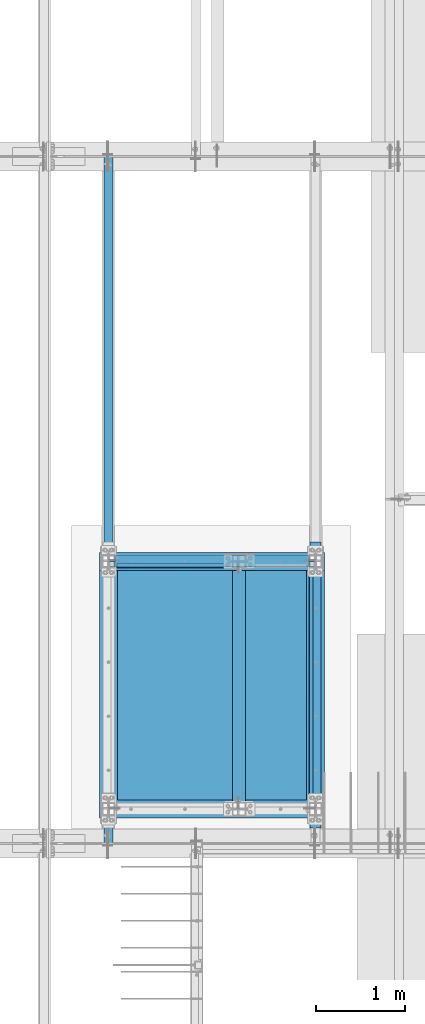
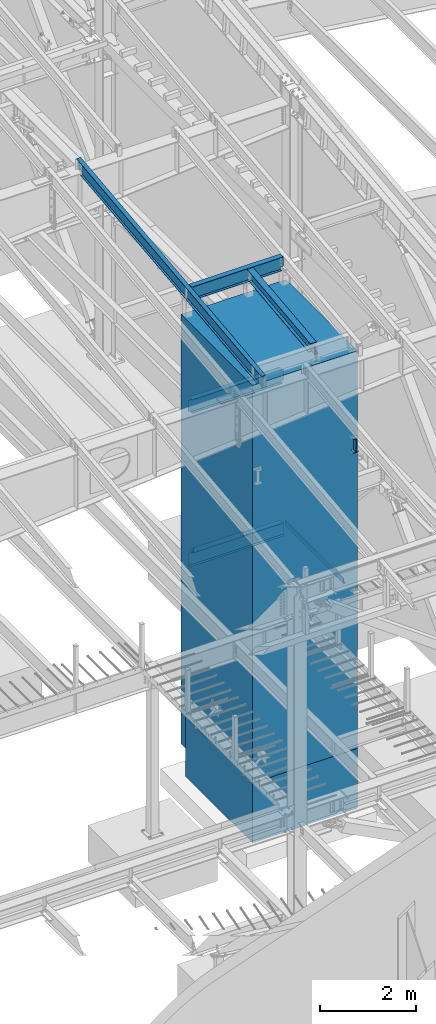
# One storey, part 722 of 1179: 11 beams, 10 elements without a shape of their own.
"""IFC2X3 building model written with IfcOpenShell, lengths in millimetres."""

import ifcopenshell
import ifcopenshell.guid

model = None  # the IFC model being written
_history = None  # IfcOwnerHistory: only IFC2X3 demands one
_inside = {}  # id of a spatial element -> (the spatial element, [elements in it])
_under = {}  # id of a project, library or spatial element -> (it, [spatial elements below it])
_declared = {}  # id of a project -> (the project, [libraries it declares])
_typed = {}  # id of a type object -> (the type object, [elements of that type])
_made_of = {}  # id of a material, layer set ... -> (it, [elements and type objects made of it])


def new_model(schema):
    """Start an empty IFC model of exactly this schema.

    Asked for "IFC4X3", IfcOpenShell would pick the latest addendum, in which some entities
    have other attributes; the version numbers below select the first issue.
    IFC2X3 requires an IfcOwnerHistory on every rooted entity: one is made here for all.
    """
    global model, _history
    if schema == "IFC4X3":
        model = ifcopenshell.file(schema_version=(4, 3, 0, 0))
    else:
        model = ifcopenshell.file(schema=schema)
    _inside.clear()
    _under.clear()
    _declared.clear()
    _typed.clear()
    _made_of.clear()
    _history = None
    if model.schema == "IFC2X3":
        org = make("IfcOrganization", Name="unknown")
        user = make(
            "IfcPersonAndOrganization",
            ThePerson=make("IfcPerson", FamilyName="unknown"),
            TheOrganization=org,
        )
        app = make(
            "IfcApplication",
            ApplicationDeveloper=org,
            Version="unknown",
            ApplicationFullName="unknown",
            ApplicationIdentifier="unknown",
        )
        _history = make(
            "IfcOwnerHistory",
            OwningUser=user,
            OwningApplication=app,
            ChangeAction="ADDED",
            CreationDate=0,
        )
    return model


def make(cls, **values):
    """One entity of the class cls with the attributes given. An attribute that is None is left unset."""
    return model.create_entity(
        cls, **{name: value for name, value in values.items() if value is not None}
    )


def rooted(cls, **values):
    """An entity with a GlobalId (a new one), such as an element, a storey or a relation."""
    return make(cls, GlobalId=ifcopenshell.guid.new(), OwnerHistory=_history, **values)


def si_unit(unit_type, name, prefix=None):
    """IfcSIUnit, for example si_unit("LENGTHUNIT", "METRE", prefix="MILLI")."""
    return make("IfcSIUnit", UnitType=unit_type, Prefix=prefix, Name=name)


def assignment(units):
    """IfcUnitAssignment: the units of a project."""
    return None if units is None else make("IfcUnitAssignment", Units=units)


def point(xyz):
    """IfcCartesianPoint."""
    return None if xyz is None else make("IfcCartesianPoint", Coordinates=xyz)


def direction(xyz):
    """IfcDirection."""
    return None if xyz is None else make("IfcDirection", DirectionRatios=xyz)


def frame(location, z_axis=None, x_axis=None):
    """IfcAxis2Placement3D, a coordinate frame: its origin and axes. An axis left out is left unset."""
    return make(
        "IfcAxis2Placement3D",
        Location=point(location),
        Axis=direction(z_axis),
        RefDirection=direction(x_axis),
    )


def origin_with_axes():
    """The frame at (0, 0, 0) with the z axis (0, 0, 1) and the x axis (1, 0, 0) written out."""
    return frame((0.0, 0.0, 0.0), z_axis=(0.0, 0.0, 1.0), x_axis=(1.0, 0.0, 0.0))


def place(relative_to, where):
    """IfcLocalPlacement: puts the frame where relative to a parent placement (None: the world)."""
    return make(
        "IfcLocalPlacement", PlacementRelTo=relative_to, RelativePlacement=where
    )


def context(
    kind, dimensions, precision=None, world=None, true_north=None, identifier=None
):
    """IfcGeometricRepresentationContext, for example the 3D "Model" context."""
    return make(
        "IfcGeometricRepresentationContext",
        ContextIdentifier=identifier,
        ContextType=kind,
        CoordinateSpaceDimension=dimensions,
        Precision=precision,
        WorldCoordinateSystem=world,
        TrueNorth=true_north,
    )


def subcontext(parent, identifier, kind, view, scale=None):
    """IfcGeometricRepresentationSubContext, for example "Body" below "Model"."""
    return make(
        "IfcGeometricRepresentationSubContext",
        ContextIdentifier=identifier,
        ContextType=kind,
        ParentContext=parent,
        TargetScale=scale,
        TargetView=view,
    )


def project(units=None, contexts=None):
    """IfcProject with its units and contexts."""
    return rooted(
        "IfcProject",
        Name="project",
        RepresentationContexts=contexts,
        UnitsInContext=assignment(units),
    )


def spatial(cls, under=None, at=None, **own):
    """A site, building, storey or space (cls), placed at a placement, below another one or the project."""
    s = rooted(cls, ObjectPlacement=at, **own)
    if under is not None:
        _under.setdefault(under.id(), (under, []))[1].append(s)
    return s


def faces_of(points, faces, orient=None, outer=None):
    """IfcFace entities. A face is a list of loops; a loop is a list of indices into points, from 0.

    orient and outer hold one flag for each loop. By default every Orientation is true, the
    first loop of a face is its IfcFaceOuterBound and the others are IfcFaceBound.
    """
    made = []
    for i, loops in enumerate(faces):
        bounds = []
        for j, loop in enumerate(loops):
            is_outer = j == 0 if outer is None else outer[i][j]
            bounds.append(
                make(
                    "IfcFaceOuterBound" if is_outer else "IfcFaceBound",
                    Bound=make("IfcPolyLoop", Polygon=[points[k] for k in loop]),
                    Orientation=True if orient is None else orient[i][j],
                )
            )
        made.append(make("IfcFace", Bounds=bounds))
    return made


def faceted_brep(points, faces, orient=None, outer=None, voids=None):
    """IfcFacetedBrep: a solid bounded by flat faces; with voids (closed shells), ...WithVoids."""
    shared = [point(p) for p in points]
    hull = make("IfcClosedShell", CfsFaces=faces_of(shared, faces, orient, outer))
    if voids is None:
        return make("IfcFacetedBrep", Outer=hull)
    return make(
        "IfcFacetedBrepWithVoids",
        Outer=hull,
        Voids=[
            make(cls, CfsFaces=faces_of(shared, fs, o, b)) for cls, fs, o, b in voids
        ],
    )


def shape(context_of_items, identifier, shape_type, items):
    """IfcShapeRepresentation: the items that make up one representation, for example the "Body"."""
    return make(
        "IfcShapeRepresentation",
        ContextOfItems=context_of_items,
        RepresentationIdentifier=identifier,
        RepresentationType=shape_type,
        Items=items,
    )


def material(Name=None, Category=None):
    """IfcMaterial."""
    return make("IfcMaterial", Name=Name, Category=Category)


def made_of(thing, what):
    """Note that an element or type object is made of a material, layer set ...; save() writes the relation."""
    if what is not None:
        _made_of.setdefault(what.id(), (what, []))[1].append(thing)
    return thing


def type_object(cls, material=None, **own):
    """A type object (cls), such as IfcWallType, which elements share."""
    return made_of(rooted(cls, **own), material)


def element(
    cls,
    number,
    at=None,
    inside=None,
    cuts=None,
    type_object=None,
    material=None,
    context=None,
    identifier="Body",
    shape_type=None,
    held_by="IfcProductDefinitionShape",
    body=None,
    shapes=None,
    **own,
):
    """One element of the class cls, such as IfcWall. Its Tag is "e" and its number.

    at: its placement. inside: the storey or other place that contains it. cuts: it is an
    opening in that element (IfcRelVoidsElement). A single representation is given by context,
    identifier, shape_type and body (its items); several are given by shapes. held_by: the class
    of the entity that holds the representations. save() writes the other relations.
    """
    e = rooted(cls, Tag="e%d" % number, ObjectPlacement=at, **own)
    if body is not None:
        shapes = [shape(context, identifier, shape_type, body)]
    if shapes is not None:
        e.Representation = make(held_by, Representations=shapes)
    if inside is not None:
        _inside.setdefault(inside.id(), (inside, []))[1].append(e)
    if cuts is not None:
        rooted(
            "IfcRelVoidsElement", RelatingBuildingElement=cuts, RelatedOpeningElement=e
        )
    if type_object is not None:
        _typed.setdefault(type_object.id(), (type_object, []))[1].append(e)
    return made_of(e, material)


def aggregate(whole, parts):
    """IfcRelAggregates: a whole, such as a stair, and the parts it consists of."""
    return rooted("IfcRelAggregates", RelatingObject=whole, RelatedObjects=parts)


def save(model, path):
    """Write the relations noted so far, then the file.

    IfcRelAggregates (storeys below a building ...), IfcRelContainedInSpatialStructure (elements
    in a storey), IfcRelDefinesByType, IfcRelAssociatesMaterial and IfcRelDeclares: one each for
    every whole, place, type object, material and project.
    """
    for whole, parts in _under.values():
        aggregate(whole, parts)
    for where, things in _inside.values():
        rooted(
            "IfcRelContainedInSpatialStructure",
            RelatedElements=things,
            RelatingStructure=where,
        )
    for kind, things in _typed.values():
        rooted("IfcRelDefinesByType", RelatedObjects=things, RelatingType=kind)
    for what, things in _made_of.values():
        rooted("IfcRelAssociatesMaterial", RelatedObjects=things, RelatingMaterial=what)
    for by, libraries in _declared.values():
        rooted("IfcRelDeclares", RelatingContext=by, RelatedDefinitions=libraries)
    model.write(path)


model = new_model("IFC2X3")

# Units and contexts
model_context = context("Model", 3, precision=1e-05, world=origin_with_axes())
body_context = subcontext(model_context, "Body", "Model", "MODEL_VIEW")
ifc_project = project(units=[si_unit("LENGTHUNIT", "METRE", prefix="MILLI"), si_unit("AREAUNIT", "SQUARE_METRE"), si_unit("VOLUMEUNIT", "CUBIC_METRE"), si_unit("MASSUNIT", "GRAM", prefix="KILO"), si_unit("TIMEUNIT", "SECOND"), si_unit("PLANEANGLEUNIT", "RADIAN"), si_unit("SOLIDANGLEUNIT", "STERADIAN"), si_unit("THERMODYNAMICTEMPERATUREUNIT", "DEGREE_CELSIUS"), si_unit("LUMINOUSINTENSITYUNIT", "LUMEN")], contexts=[model_context])

# Site, building, storey
site_placement = place(None, origin_with_axes())
site = spatial("IfcSite", under=ifc_project, at=site_placement, CompositionType="ELEMENT")
building_placement = place(site_placement, origin_with_axes())
building = spatial("IfcBuilding", under=site, at=building_placement, Name="Undefined", CompositionType="ELEMENT")
storey_placement = place(building_placement, origin_with_axes())
storey = spatial("IfcBuildingStorey", under=building, at=storey_placement, Name="Undefined", CompositionType="ELEMENT", Elevation=0.0)

# Assembly, beam
assembly_1_placement = place(storey_placement, origin_with_axes())
assembly_1 = element("IfcElementAssembly", 1, at=assembly_1_placement, inside=storey, Name="BEAM", AssemblyPlace="NOTDEFINED", PredefinedType="RIGID_FRAME")
ifc_material_1 = material(Name="STEEL/A992")
beam_type_1 = type_object("IfcBeamType", Name="W10X22", PredefinedType="NOTDEFINED")
beam_1_placement = place(assembly_1_placement, frame((20612.1000000001, 11882.5883300328, 10453.0155913628), z_axis=(0.0, -0.112284087038017, 0.993676146336441), x_axis=(0.0, 0.993676146336441, 0.112284087038017)))
beam_1 = element("IfcBeam", 2, at=beam_1_placement, type_object=beam_type_1, material=ifc_material_1, Name="BEAM", ObjectType="W10X22", context=body_context, shape_type="Brep", body=[
    faceted_brep([(114.643012563729, 3.37393741607593, -119.062499999978), (114.643012563725, 3.37393741607593, -128.587499999972), (-13.0844039856984, 3.37393741607593, -128.587499999921), (-12.0080916147308, 3.17499999999927, -119.062499999927), (114.643012563729, 73.0250000000015, -119.062499999978), (114.643012563725, 73.0250000000015, -128.587499999972), (75.608631949508, 3.17499999999927, 119.062499999904), (75.608631949508, 73.0250000000015, 119.062499999904), (2734.02003668513, 73.0250000000015, 119.062499998825), (2734.02003668513, 3.17499999999927, 119.062499998825), (76.6849443204737, -73.0250000000015, 128.587499999898), (76.6849443204737, 73.0250000000015, 128.587499999898), (74.2065444502277, 3.17499999999927, 106.654500435005), (74.2065444502277, -3.17499999999927, 106.654500435005), (75.608631949508, -3.17499999999927, 119.062499999904), (75.608631949508, -73.0250000000015, 119.062499999904), (72.700218394586, 3.17499999999927, 101.9337037354), (72.700218394586, -3.17499999999927, 101.9337037354), (69.5019838979915, 3.17499999999927, 98.1487023127211), (69.5019838979915, -3.17499999999927, 98.1487023127211), (65.0987431704762, 3.17499999999927, 95.8757283224459), (65.0987431704762, -3.17499999999927, 95.8757283224459), (60.1608496973295, 3.17499999999927, 95.4608214500367), (60.1608496973295, -3.17499999999927, 95.4608214500367), (12.8370230384862, 3.17499999999927, 100.808351116644), (12.8370230384862, -3.17499999999927, 100.808351116644), (-12.0080916147308, -3.17499999999927, -119.062499999927), (-12.0080916147308, -73.0250000000015, -119.062499999927), (2767.82114171815, -73.0250000000015, -119.062500001055), (2767.82114171815, -3.17499999999927, -119.062500001055), (-13.0844039856984, -73.0250000000015, -128.587499999921), (2766.74482934718, -73.0250000000015, -128.587500001049), (2639.01741279884, 3.17499999999927, -119.062500001002), (2639.01741279883, 3.37393741607593, -128.587500000996), (2639.01741279883, 73.0250000000015, -128.587500000996), (2639.01741279884, 73.0250000000015, -119.062500001002), (2767.82114171815, 3.17499999999927, -119.062500001055), (2766.74482934718, 3.37393741607593, -128.587500001049), (2773.92024515364, 3.17499999999927, -65.0875000010201), (2791.45772885094, 3.17499999999927, 90.1132918162257), (2791.45772885094, -3.17499999999927, 90.1132918162257), (2739.41310547559, -3.17499999999927, 96.9671475403811), (2735.62810405291, -3.17499999999927, 100.165382036977), (2733.35513006264, -3.17499999999927, 104.568622764493), (2732.94022319023, -3.17499999999927, 109.506516237638), (2734.02003668513, -3.17499999999927, 119.062499998825), (2744.13390217519, -3.17499999999927, 95.4608214847431), (2734.02003668513, -73.0250000000015, 119.062499998825), (2735.0963490561, -73.0250000000015, 128.587499998819), (2735.0963490561, 73.0250000000015, 128.587499998819), (2732.94022319023, 3.17499999999927, 109.506516237638), (2733.35513006264, 3.17499999999927, 104.568622764493), (2735.62810405291, 3.17499999999927, 100.165382036977), (2739.41310547559, 3.17499999999927, 96.9671475403811), (2744.13390217519, 3.17499999999927, 95.4608214847431), (-5.90898817924426, 3.17499999999927, -65.0874999998869)], [[[0, 1, 2, 3]], [[4, 5, 1, 0]], [[6, 7, 8, 9]], [[10, 11, 7, 6, 12, 13, 14, 15]], [[13, 12, 16, 17]], [[17, 16, 18, 19]], [[19, 18, 20, 21]], [[21, 20, 22, 23]], [[23, 22, 24, 25]], [[26, 27, 28, 29]], [[27, 30, 31, 28]], [[32, 33, 34, 35]], [[36, 37, 33, 32]], [[38, 39, 40, 29, 28, 31, 37, 36]], [[41, 42, 43, 44, 45, 14, 13, 17, 19, 21, 23, 25, 26, 29, 40, 46]], [[15, 14, 45, 47]], [[10, 15, 47, 48]], [[11, 10, 48, 49]], [[7, 11, 49, 8]], [[48, 47, 45, 44, 50, 9, 8, 49]], [[43, 51, 50, 44]], [[42, 52, 51, 43]], [[41, 53, 52, 42]], [[46, 54, 53, 41]], [[40, 39, 54, 46]], [[38, 36, 32, 0, 3, 55, 24, 22, 20, 18, 16, 12, 6, 9, 50, 51, 52, 53, 54, 39]], [[30, 27, 26, 25, 24, 55, 3, 2]], [[34, 33, 37, 31, 30, 2, 1, 5]], [[35, 34, 5, 4]], [[32, 35, 4, 0]]]),
])
aggregate(assembly_1, [beam_1])

assembly_2_placement = place(storey_placement, origin_with_axes())
assembly_2 = element("IfcElementAssembly", 3, at=assembly_2_placement, inside=storey, Name="BEAM", AssemblyPlace="NOTDEFINED", PredefinedType="RIGID_FRAME")
ifc_material_2 = material(Name="STEEL/A36")
beam_type_2 = type_object("IfcBeamType", PredefinedType="NOTDEFINED")
beam_2_placement = place(assembly_2_placement, frame((19837.4000030518, 14589.125, 4235.45000610352), z_axis=(1.0, 0.0, 0.0), x_axis=(0.0, 0.0, -1.0)))
beam_2 = element("IfcBeam", 4, at=beam_2_placement, type_object=beam_type_2, material=ifc_material_2, Name="BENT_PLATE", context=body_context, shape_type="Brep", body=[
    faceted_brep([(0.0, -3.17499999999927, -603.25), (0.0, -3.17499999999927, 603.25), (0.0, 3.17499999999927, 603.25), (0.0, 3.17499999999927, -603.25), (127.000006103516, 3.17499999999927, 603.25), (127.000006103516, 3.17499999999927, -603.25), (133.350006103517, -3.17499999999927, -603.25), (133.350006103517, -3.17499999999927, 603.25), (127.000006103516, 47.6250000000018, 603.25), (127.000006103516, 47.6250000000018, -603.25), (133.350006103517, 47.6250000000018, 603.25), (133.350006103517, 47.6250000000018, -603.25)], [[[0, 1, 2, 3]], [[3, 2, 4, 5]], [[1, 0, 6, 7]], [[5, 4, 8, 9]], [[4, 2, 1, 7, 10, 8]], [[7, 6, 11, 10]], [[6, 0, 3, 5, 9, 11]], [[10, 11, 9, 8]]]),
])

assembly_3_placement = place(storey_placement, origin_with_axes())
assembly_3 = element("IfcElementAssembly", 5, at=assembly_3_placement, inside=storey, Name="BEAM", AssemblyPlace="NOTDEFINED", PredefinedType="RIGID_FRAME")
beam_type_3 = type_object("IfcBeamType", Name="W14X22", PredefinedType="NOTDEFINED")
beam_3_placement = place(assembly_3_placement, frame((19138.9, 14662.15, 10721.8832183146), z_axis=(0.0, 0.0, 1.0), x_axis=(1.0, 0.0, 0.0)))
beam_3 = element("IfcBeam", 6, at=beam_3_placement, type_object=beam_type_3, material=ifc_material_1, Name="BEAM", ObjectType="W14X22", context=body_context, shape_type="Brep", body=[
    faceted_brep([(2244.725, -3.17499999999927, -166.6875), (2244.725, -63.5, -166.6875), (2244.725, -63.5, -174.625), (2244.725, 63.5, -174.625), (2244.725, 63.5, -166.6875), (2244.725, 3.17499999999927, -166.6875), (2244.725, 3.17499999999927, -123.824999806495), (2244.725, -3.17499999999927, -123.824999806495), (2245.69172992259, 3.17499999999927, -118.964920288448), (2245.69172992259, -3.17499999999927, -118.964920288448), (2248.44474382306, 3.17499999999927, -114.844743820295), (2248.44474382306, -3.17499999999927, -114.844743820295), (2252.56492029122, 3.17499999999927, -112.091729919817), (2252.56492029122, -3.17499999999927, -112.091729919817), (2257.42499980926, 3.17499999999927, -111.12499999723), (2257.42499980926, -3.17499999999927, -111.12499999723), (2320.925, -3.17499999999927, -111.12499999723), (2320.925, 3.17499999999927, -111.12499999723), (66.6749999999993, 3.17499999999927, 166.6875), (66.6749999999993, 63.5, 166.6875), (2270.125, 63.5, 166.6875), (2270.125, 3.17499999999927, 166.6875), (92.0750000000007, -3.17499999999927, -123.824999806491), (92.0750000000007, 3.17499999999927, -123.824999806491), (92.0750000000007, 3.17499999999927, -166.6875), (92.0750000000007, 63.5, -166.6875), (92.0750000000007, 63.5, -174.625), (92.0750000000007, -63.5, -174.625), (92.0750000000007, -63.5, -166.6875), (92.0750000000007, -3.17499999999927, -166.6875), (91.1082700774132, -3.17499999999927, -118.964920288445), (91.1082700774132, 3.17499999999927, -118.964920288445), (88.3552561769357, -3.17499999999927, -114.844743820291), (88.3552561769357, 3.17499999999927, -114.844743820291), (84.235079708782, -3.17499999999927, -112.091729919814), (84.235079708782, 3.17499999999927, -112.091729919814), (79.3750001907356, -3.17499999999927, -111.124999997226), (79.3750001907356, 3.17499999999927, -111.124999997226), (15.875, -3.17499999999927, -111.124999997226), (15.875, 3.17499999999927, -111.124999997226), (15.875, -3.17499999999927, 149.225000002774), (15.875, 3.17499999999927, 149.225000002774), (53.9750001907341, -3.17499999999927, 149.225000002774), (53.9750001907341, 3.17499999999927, 149.225000002774), (58.8350797087805, -3.17499999999927, 150.191729925362), (58.8350797087805, 3.17499999999927, 150.191729925362), (62.9552561769342, -3.17499999999927, 152.944743825839), (62.9552561769342, 3.17499999999927, 152.944743825839), (65.7082700774117, -3.17499999999927, 157.064920293993), (65.7082700774117, 3.17499999999927, 157.064920293993), (66.6749999999993, -3.17499999999927, 161.924999812039), (66.6749999999993, 3.17499999999927, 161.924999812039), (66.6749999999993, -63.5, 174.625), (66.6749999999993, 63.5, 174.625), (66.6749999999993, -3.17499999999927, 166.6875), (66.6749999999993, -63.5, 166.6875), (2270.125, -3.17499999999927, 166.6875), (2270.125, -63.5, 166.6875), (2270.125, -63.5, 174.625), (2270.125, 63.5, 174.625), (2270.125, -3.17499999999927, 161.924999812036), (2270.125, 3.17499999999927, 161.924999812036), (2271.09172992259, -3.17499999999927, 157.064920293989), (2271.09172992259, 3.17499999999927, 157.064920293989), (2273.84474382307, -3.17499999999927, 152.944743825836), (2273.84474382307, 3.17499999999927, 152.944743825836), (2277.96492029122, -3.17499999999927, 150.191729925358), (2277.96492029122, 3.17499999999927, 150.191729925358), (2282.82499980927, -3.17499999999927, 149.225000002771), (2282.82499980927, 3.17499999999927, 149.225000002771), (2320.925, -3.17499999999927, 149.225000002771), (2320.925, 3.17499999999927, 149.225000002771)], [[[0, 1, 2, 3, 4, 5, 6, 7]], [[7, 6, 8, 9]], [[9, 8, 10, 11]], [[11, 10, 12, 13]], [[13, 12, 14, 15]], [[16, 15, 14, 17]], [[18, 19, 20, 21]], [[22, 23, 24, 25, 26, 27, 28, 29]], [[30, 31, 23, 22]], [[32, 33, 31, 30]], [[34, 35, 33, 32]], [[36, 37, 35, 34]], [[38, 39, 37, 36]], [[40, 41, 39, 38]], [[42, 43, 41, 40]], [[44, 45, 43, 42]], [[46, 47, 45, 44]], [[48, 49, 47, 46]], [[50, 51, 49, 48]], [[52, 53, 19, 18, 51, 50, 54, 55]], [[55, 54, 56, 57]], [[52, 55, 57, 58]], [[53, 52, 58, 59]], [[19, 53, 59, 20]], [[58, 57, 56, 60, 61, 21, 20, 59]], [[62, 63, 61, 60]], [[64, 65, 63, 62]], [[66, 67, 65, 64]], [[68, 69, 67, 66]], [[70, 71, 69, 68]], [[71, 70, 16, 17]], [[12, 10, 8, 6, 5, 24, 23, 31, 33, 35, 37, 39, 41, 43, 45, 47, 49, 51, 18, 21, 61, 63, 65, 67, 69, 71, 17, 14]], [[25, 24, 5, 4]], [[26, 25, 4, 3]], [[27, 26, 3, 2]], [[28, 27, 2, 1]], [[29, 28, 1, 0]], [[70, 68, 66, 64, 62, 60, 56, 54, 50, 48, 46, 44, 42, 40, 38, 36, 34, 32, 30, 22, 29, 0, 7, 9, 11, 13, 15, 16]]]),
])
aggregate(assembly_3, [beam_3])

assembly_4_placement = place(storey_placement, origin_with_axes())
assembly_4 = element("IfcElementAssembly", 7, at=assembly_4_placement, inside=storey, Name="BEAM", AssemblyPlace="NOTDEFINED", PredefinedType="RIGID_FRAME")
beam_4_placement = place(assembly_4_placement, frame((21475.7, 11652.2500015259, 7839.075), z_axis=(0.0, 0.0, 1.0), x_axis=(0.0, 1.0, 0.0)))
beam_4 = element("IfcBeam", 8, at=beam_4_placement, type_object=beam_type_3, material=ifc_material_1, Name="BEAM", ObjectType="W14X22", context=body_context, shape_type="Brep", body=[
    faceted_brep([(0.0, 63.5, -174.625), (0.0, 63.5, -166.6875), (3225.79999694824, 63.5, -166.6875), (3225.79999694824, 63.5, -174.625), (-1.21872290037572e-10, 3.17500000000018, -166.687500000036), (3225.79999694824, 3.17499999999927, -166.6875), (1.20053300634027e-10, 3.17500000000018, 166.687500000036), (3225.79999694824, 3.17499999999927, 166.6875), (0.0, 63.5, 166.6875), (3225.79999694824, 63.5, 166.6875), (0.0, 63.5, 174.625), (3225.79999694824, 63.5, 174.625), (0.0, -63.5, 174.625), (3225.79999694824, -63.5, 174.625), (0.0, -63.5, 166.6875), (3225.79999694824, -63.5, 166.6875), (1.20053300634027e-10, -3.17500000000018, 166.687500000036), (3225.79999694824, -3.17499999999927, 166.6875), (-1.21872290037572e-10, -3.17500000000018, -166.687500000036), (3225.79999694824, -3.17499999999927, -166.6875), (0.0, -63.5, -166.6875), (3225.79999694824, -63.5, -166.6875), (0.0, -63.5, -174.625), (3225.79999694824, -63.5, -174.625)], [[[0, 1, 2, 3]], [[1, 4, 5, 2]], [[4, 6, 7, 5]], [[6, 8, 9, 7]], [[8, 10, 11, 9]], [[10, 12, 13, 11]], [[12, 14, 15, 13]], [[14, 16, 17, 15]], [[16, 18, 19, 17]], [[18, 20, 21, 19]], [[20, 22, 23, 21]], [[22, 0, 3, 23]], [[5, 7, 9, 11, 13, 15, 17, 19, 21, 23, 3, 2]], [[22, 20, 18, 16, 14, 12, 10, 8, 6, 4, 1, 0]]]),
])
aggregate(assembly_4, [beam_4])

assembly_5_placement = place(storey_placement, origin_with_axes())
assembly_5 = element("IfcElementAssembly", 9, at=assembly_5_placement, inside=storey, Name="BEAM", AssemblyPlace="NOTDEFINED", PredefinedType="RIGID_FRAME")
beam_5_placement = place(assembly_5_placement, frame((19138.9, 14662.15, 7839.075), z_axis=(0.0, 0.0, 1.0), x_axis=(1.0, 0.0, 0.0)))
beam_5 = element("IfcBeam", 10, at=beam_5_placement, type_object=beam_type_3, material=ifc_material_1, Name="BEAM", ObjectType="W14X22", context=body_context, shape_type="Brep", body=[
    faceted_brep([(15.8749999999964, -3.17499999999927, -142.875), (15.8749999999964, 3.17499999999927, -142.875), (66.6750001907349, 3.17499999999927, -142.875), (66.6750001907349, -3.17499999999927, -142.875), (71.5350797087813, 3.17499999999927, -143.841729922588), (71.5350797087813, -3.17499999999927, -143.841729922588), (75.6552561769349, 3.17499999999927, -146.594743823066), (75.6552561769349, -3.17499999999927, -146.594743823066), (78.4082700774125, 3.17499999999927, -150.71492029122), (78.4082700774125, -3.17499999999927, -150.71492029122), (79.375, -3.17499999999927, -155.574999809265), (79.375, 3.17499999999927, -155.574999809265), (79.375, 3.17499999999927, -166.6875), (79.375, 63.5, -166.6875), (79.375, 63.5, -174.625), (79.375, -63.5, -174.625), (79.375, -63.5, -166.6875), (79.375, -3.17499999999927, -166.6875), (76.2000000000007, 3.17499999999927, 166.6875), (76.2000000000007, 63.5, 166.6875), (2260.59999999999, 63.5, 166.6875), (2260.59999999999, 3.17499999999927, 166.6875), (63.5, -3.17499999993015, 142.874999807531), (63.5, 3.1750000039101, 142.874999807529), (15.8750000000018, 3.17500000000291, 142.874999999998), (15.8750000000018, -3.17500000000291, 142.874999999998), (68.360079708782, -3.17499999999927, 143.841729922588), (68.360079708782, 3.17499999999927, 143.841729922588), (72.4802561769357, -3.17499999999927, 146.594743823066), (72.4802561769357, 3.17499999999927, 146.594743823066), (75.2332700774132, -3.17499999999927, 150.71492029122), (75.2332700774132, 3.17499999999927, 150.71492029122), (76.2000000000007, -3.17499999999927, 155.574999809265), (76.2000000000007, 3.17499999999927, 155.574999809265), (76.2000000000007, 63.5, 174.625), (76.2000000000007, -63.5, 174.625), (2260.59999999999, -63.5, 174.625), (2260.59999999999, 63.5, 174.625), (76.2000000000007, -63.5, 166.6875), (2260.59999999999, -63.5, 166.6875), (76.2000000000007, -3.17499999999927, 166.6875), (2260.59999999999, -3.17499999999927, 166.6875), (2260.59999999999, -3.17499999999927, 155.574999809265), (2260.59999999999, 3.17499999999927, 155.574999809265), (2261.56672992258, -3.17499999999927, 150.71492029122), (2261.56672992258, 3.17499999999927, 150.71492029122), (2264.31974382306, -3.17499999999927, 146.594743823066), (2264.31974382306, 3.17499999999927, 146.594743823066), (2268.43992029121, -3.17499999999927, 143.841729922588), (2268.43992029121, 3.17499999999927, 143.841729922588), (2273.29999980926, -3.17499999999927, 142.875), (2273.29999980926, 3.17499999999927, 142.875), (2320.925, -3.17499999999927, 142.875), (2320.925, 3.17499999999927, 142.875), (2320.925, -3.17499999999927, -142.875), (2320.925, 3.17499999999927, -142.875), (2270.12499980926, -3.17499999999927, -142.875), (2270.12499980926, 3.17499999999927, -142.875), (2265.26492029121, -3.17499999999927, -143.841729922588), (2265.26492029121, 3.17499999999927, -143.841729922588), (2261.14474382306, -3.17499999999927, -146.594743823066), (2261.14474382306, 3.17499999999927, -146.594743823066), (2258.39172992258, -3.17499999999927, -150.71492029122), (2258.39172992258, 3.17499999999927, -150.71492029122), (2257.42499999999, -3.17499999999927, -155.574999809265), (2257.42499999999, 3.17499999999927, -155.574999809265), (2257.42499999999, -3.17499999999927, -166.6875), (2257.42499999999, -63.5, -166.6875), (2257.42499999999, -63.5, -174.625), (2257.42499999999, 63.5, -174.625), (2257.42499999999, 63.5, -166.6875), (2257.42499999999, 3.17499999999927, -166.6875)], [[[0, 1, 2, 3]], [[3, 2, 4, 5]], [[5, 4, 6, 7]], [[7, 6, 8, 9]], [[10, 11, 12, 13, 14, 15, 16, 17]], [[9, 8, 11, 10]], [[18, 19, 20, 21]], [[22, 23, 24, 25]], [[26, 27, 23, 22]], [[28, 29, 27, 26]], [[30, 31, 29, 28]], [[32, 33, 31, 30]], [[34, 35, 36, 37]], [[35, 38, 39, 36]], [[38, 40, 41, 39]], [[35, 34, 19, 18, 33, 32, 40, 38]], [[19, 34, 37, 20]], [[36, 39, 41, 42, 43, 21, 20, 37]], [[44, 45, 43, 42]], [[46, 47, 45, 44]], [[48, 49, 47, 46]], [[50, 51, 49, 48]], [[52, 53, 51, 50]], [[53, 52, 54, 55]], [[54, 56, 57, 55]], [[58, 59, 57, 56]], [[60, 61, 59, 58]], [[62, 63, 61, 60]], [[64, 65, 63, 62]], [[66, 67, 68, 69, 70, 71, 65, 64]], [[17, 16, 67, 66]], [[16, 15, 68, 67]], [[15, 14, 69, 68]], [[14, 13, 70, 69]], [[13, 12, 71, 70]], [[59, 61, 63, 65, 71, 12, 11, 8, 6, 4, 2, 1, 24, 23, 27, 29, 31, 33, 18, 21, 43, 45, 47, 49, 51, 53, 55, 57]], [[25, 24, 1, 0]], [[52, 50, 48, 46, 44, 42, 41, 40, 32, 30, 28, 26, 22, 25, 0, 3, 5, 7, 9, 10, 17, 66, 64, 62, 60, 58, 56, 54]]]),
])
aggregate(assembly_5, [beam_5])

# Beam
beam_6_placement = place(assembly_2_placement, frame((19138.9, 14662.15, 3927.475), z_axis=(0.0, 0.0, 1.0), x_axis=(1.0, 0.0, 0.0)))
beam_6 = element("IfcBeam", 11, at=beam_6_placement, type_object=beam_type_3, material=ifc_material_1, Name="BEAM", ObjectType="W14X22", context=body_context, shape_type="Brep", body=[
    faceted_brep([(69.8500001907341, -3.17500000000291, 142.874999999998), (69.8500001907341, 3.17497569180705, 142.874999999998), (15.8750000000018, 3.17500000000291, 142.874999999998), (15.8750000000018, -3.17500000000291, 142.874999999998), (74.7100797087805, -3.17500000000291, 143.841729922586), (74.7100797087805, 3.17497496696888, 143.841729922586), (78.8302561769342, -3.17500000000291, 146.594743823063), (78.8302561769342, 3.17497290281608, 146.594743823063), (81.5832700774117, -3.17500000000291, 150.714920291217), (81.5832700774117, 3.17496981359, 150.714920291217), (82.5499999999993, -3.17500000000291, 155.574999809263), (82.5499999999993, 3.17496616959397, 155.574999809263), (82.5499999999993, -63.5, 174.625), (82.5499999999993, 63.5, 174.625), (82.5499999999993, 63.5, 166.6875), (82.5499999999993, 3.17500000000291, 166.6875), (82.5499999999993, -3.17500000000291, 166.6875), (82.5499999999993, -63.5, 166.6875), (142.875000000002, 63.5, -166.6875), (142.875000000002, 3.17549991607666, -166.6875), (2193.92499999986, 3.17502914962461, -166.6875), (2193.925, 63.5, -166.6875), (15.8750000000018, -3.17500000000291, -166.6875), (15.8750000000018, -63.5, -166.6875), (2320.925, -63.5, -166.6875), (2320.925, -3.17499999999927, -166.6875), (15.8750000000018, -63.5, -174.625), (2320.925, -63.5, -174.625), (2193.925, 63.5, -174.625), (2193.925, 3.17549991607666, -174.625), (2320.925, 3.17549991607666, -174.625), (15.8750000000018, 3.17549991607666, -174.625), (142.875000000002, 3.17549991607666, -174.625), (142.875000000002, 63.5, -174.625), (15.8750000000018, 3.17500000000291, -166.6875), (2320.925, 3.17499999999927, -166.6875), (2320.925, 3.17499999999927, 142.875), (2320.925, -3.17499999999927, 142.875), (2266.94999980927, 3.17496467120691, 142.875), (2266.94999980927, -3.17499999999927, 142.875), (2262.08992029122, 3.17496394012414, 143.841729922588), (2262.08992029122, -3.17499999999927, 143.841729922588), (2257.96974382307, 3.17496186523749, 146.594743823066), (2257.96974382307, -3.17499999999927, 146.594743823066), (2255.21672992259, 3.17495876243083, 150.71492029122), (2255.21672992259, -3.17499999999927, 150.71492029122), (2254.25, 3.17495510407934, 155.574999809265), (2254.25, -3.17499999999927, 155.574999809265), (2254.25, -63.5, 174.625), (2254.25, -63.5, 166.6875), (2254.25, -3.17499999999927, 166.6875), (2254.25, 3.17499999999927, 166.6875), (2254.25, 63.5, 166.6875), (2254.25, 63.5, 174.625)], [[[0, 1, 2, 3]], [[4, 5, 1, 0]], [[6, 7, 5, 4]], [[8, 9, 7, 6]], [[10, 11, 9, 8]], [[12, 13, 14, 15, 11, 10, 16, 17]], [[18, 19, 20, 21]], [[22, 23, 24, 25]], [[23, 26, 27, 24]], [[28, 29, 30, 27, 26, 31, 32, 33]], [[19, 32, 31, 34]], [[18, 33, 32, 19]], [[33, 18, 21, 28]], [[20, 29, 28, 21]], [[35, 30, 29, 20]], [[25, 24, 27, 30, 35, 36, 37]], [[37, 36, 38, 39]], [[39, 38, 40, 41]], [[41, 40, 42, 43]], [[43, 42, 44, 45]], [[45, 44, 46, 47]], [[48, 49, 50, 47, 46, 51, 52, 53]], [[12, 17, 49, 48]], [[17, 16, 50, 49]], [[41, 43, 45, 47, 50, 16, 10, 8, 6, 4, 0, 3, 22, 25, 37, 39]], [[34, 31, 26, 23, 22, 3, 2]], [[35, 20, 19, 34, 2, 1, 5, 7, 9, 11, 15, 51, 46, 44, 42, 40, 38, 36]], [[15, 14, 52, 51]], [[14, 13, 53, 52]], [[13, 12, 48, 53]]]),
])

aggregate(assembly_2, [beam_2, beam_6])

# Assembly, beam
assembly_6_placement = place(storey_placement, origin_with_axes())
assembly_6 = element("IfcElementAssembly", 12, at=assembly_6_placement, inside=storey, Name="BEAM", AssemblyPlace="NOTDEFINED", PredefinedType="RIGID_FRAME")
beam_type_4 = type_object("IfcBeamType", PredefinedType="NOTDEFINED")
beam_7_placement = place(assembly_6_placement, frame((21443.9500015259, 13265.149512207, 4105.275), z_axis=(0.0, -1.0, 0.0), x_axis=(-1.0, 0.0, 0.0)))
beam_7 = element("IfcBeam", 13, at=beam_7_placement, type_object=beam_type_4, material=ifc_material_2, Name="BENT_PLATE", context=body_context, shape_type="Brep", body=[
    faceted_brep([(-2.00088834390044e-10, -3.17500000000018, -1225.55), (2.05545802600682e-10, -3.17500000000018, 1225.55), (2.05545802600682e-10, 3.17500000000018, 1225.55), (-2.00088834390044e-10, 3.17500000000018, -1225.55), (44.4502379994137, 3.17500000000018, 1225.55), (44.4502379990063, 3.17500000000018, -1225.55000000001), (38.1002379990059, -3.17500000000018, -1225.55000000001), (38.1002379994134, -3.17500000000018, 1225.55), (44.4502379994137, -130.175006103521, 1225.55), (44.4502379990063, -130.175006103521, -1225.55000000001), (38.1002379994134, -130.175006103521, 1225.55), (38.1002379990059, -130.175006103521, -1225.55000000001)], [[[0, 1, 2, 3]], [[3, 2, 4, 5]], [[1, 0, 6, 7]], [[5, 4, 8, 9]], [[4, 2, 1, 7, 10, 8]], [[7, 6, 11, 10]], [[6, 0, 3, 5, 9, 11]], [[10, 11, 9, 8]]]),
])
aggregate(assembly_6, [beam_7])

assembly_7_placement = place(storey_placement, origin_with_axes())
assembly_7 = element("IfcElementAssembly", 14, at=assembly_7_placement, inside=storey, Name="BEAM", AssemblyPlace="NOTDEFINED", PredefinedType="REINFORCEMENT_UNIT")
ifc_material_3 = material(Name="CONCRETE/5000")
beam_type_5 = type_object("IfcBeamType", PredefinedType="NOTDEFINED")
beam_8_placement = place(assembly_7_placement, frame((19138.9, 14662.1499984741, 5080.0), z_axis=(0.0, 0.0, 1.0), x_axis=(0.0, -1.0, 0.0)))
beam_8 = element("IfcBeam", 15, at=beam_8_placement, type_object=beam_type_5, material=ifc_material_3, Name="BEAM", context=body_context, shape_type="Brep", body=[
    faceted_brep([(0.0, -101.599999999999, -5080.0), (0.0, -101.599999999999, 5080.0), (0.0, 101.599999999999, 5080.0), (0.0, 101.599999999999, -5080.0), (2692.39990081787, 101.599999999999, 5080.0), (2692.39990081787, 101.599999999999, -5080.0), (2895.59990081787, -101.599999999999, -5080.0), (2895.59990081787, -101.599999999999, 5080.0), (2692.39990081787, 2235.19981178977, 5080.0), (2692.39990081787, 2235.19981178977, -5080.0), (2895.59990081787, 2438.39979758523, -5080.0), (2895.59990081787, 2438.39979758523, 5080.0), (101.599998474123, 2235.19999289773, 5080.0), (101.599998474123, 2235.19999289773, -5080.0), (-101.600001525878, 2438.40000710227, -5080.0), (-101.600001525878, 2438.40000710227, 5080.0), (101.599998474121, -101.600000000002, 5080.0), (101.599998474121, -101.600000000002, -5080.0), (-101.60000152588, -101.600000000002, 5080.0), (-101.60000152588, -101.600000000002, -5080.0)], [[[0, 1, 2, 3]], [[3, 2, 4, 5]], [[1, 0, 6, 7]], [[5, 4, 8, 9]], [[7, 6, 10, 11]], [[9, 8, 12, 13]], [[11, 10, 14, 15]], [[13, 12, 16, 17]], [[12, 8, 4, 2, 1, 7, 11, 15, 18, 16]], [[15, 14, 19, 18]], [[14, 10, 6, 0, 3, 5, 9, 13, 17, 19]], [[18, 19, 17, 16]]]),
])
aggregate(assembly_7, [beam_8])

assembly_8_placement = place(storey_placement, origin_with_axes())
assembly_8 = element("IfcElementAssembly", 16, at=assembly_8_placement, inside=storey, Name="BEAM", AssemblyPlace="NOTDEFINED", PredefinedType="RIGID_FRAME")
beam_type_6 = type_object("IfcBeamType", Name="W12X22", PredefinedType="NOTDEFINED")
beam_9_placement = place(assembly_8_placement, frame((19138.9, 11498.2779321842, 10389.6051906331), z_axis=(0.0, -0.112284087038017, 0.993676146336441), x_axis=(0.0, 0.993676146336441, 0.112284087038017)))
beam_9 = element("IfcBeam", 17, at=beam_9_placement, type_object=beam_type_6, material=ifc_material_1, Name="BEAM", ObjectType="W12X22", context=body_context, shape_type="Brep", body=[
    faceted_brep([(7583.46730043383, -3.17499999999927, -144.462500002994), (7583.46730043383, -50.7999999999993, -144.462500002994), (7582.21160266769, -50.7999999999993, -155.575000002988), (7582.21160266769, 50.7999999999993, -155.575000002988), (7583.46730043383, 50.7999999999993, -144.462500002994), (7583.46730043383, 3.17499999999927, -144.462500002994), (7586.83832669432, 3.17499999999927, -114.630059163946), (7586.83832669432, -3.17499999999927, -114.630059163946), (7588.34465274973, 3.17499999999927, -109.909262464753), (7588.34465274973, -3.17499999999927, -109.909262464753), (7591.54288724583, 3.17499999999927, -106.124261042249), (7591.54288724583, -3.17499999999927, -106.124261042249), (7595.94612797272, 3.17499999999927, -103.851287051781), (7595.94612797272, -3.17499999999927, -103.851287051781), (7600.88402144536, 3.17499999999927, -103.436380178771), (7600.88402144536, -3.17499999999927, -103.436380178771), (7758.6208335002, -3.17499999999927, -121.260430776909), (7758.62083354224, 3.17499999999927, -121.26043078166), (6.38101702707718, -50.7999999999993, 155.574999999912), (5.12531926095107, -50.7999999999993, 144.46249999992), (7788.64717240277, -50.7999999999993, 144.462499996762), (7789.9028701689, -50.7999999999993, 155.574999996754), (6.38101702707718, 50.7999999999993, 155.574999999912), (7789.9028701689, 50.7999999999993, 155.574999996754), (5.12531926095107, 50.7999999999993, 144.46249999992), (7788.64717240277, 50.7999999999993, 144.462499996762), (5.12531926095107, 3.17499999999927, 144.46249999992), (7788.64717240277, 3.17499999999927, 144.462499996762), (145.30344487597, -3.17499999999927, -142.022226300664), (145.30344487597, 3.17499999999927, -142.022226300664), (145.027696926005, 3.17499999999927, -144.462499999976), (145.027696926005, 50.7999999999993, -144.462499999976), (143.771999161854, 50.7999999999993, -155.574999999972), (143.771999161854, -50.7999999999993, -155.574999999972), (145.027696926005, -50.7999999999993, -144.462499999976), (145.027696926005, -3.17499999999927, -144.462499999976), (-25.0716067072917, -3.17499999999927, -122.770071196437), (-25.0716067072917, 3.17499999999927, -122.770071196437), (5.12531926095107, -3.17499999999927, 144.46249999992), (7788.64717240277, -3.17499999999927, 144.462499996762)], [[[0, 1, 2, 3, 4, 5, 6, 7]], [[7, 6, 8, 9]], [[9, 8, 10, 11]], [[11, 10, 12, 13]], [[13, 12, 14, 15]], [[16, 15, 14, 17]], [[18, 19, 20, 21]], [[22, 18, 21, 23]], [[24, 22, 23, 25]], [[26, 24, 25, 27]], [[28, 29, 30, 31, 32, 33, 34, 35]], [[36, 37, 29, 28]], [[38, 19, 18, 22, 24, 26, 37, 36]], [[19, 38, 39, 20]], [[27, 25, 23, 21, 20, 39, 16, 17]], [[12, 10, 8, 6, 5, 30, 29, 37, 26, 27, 17, 14]], [[31, 30, 5, 4]], [[32, 31, 4, 3]], [[33, 32, 3, 2]], [[34, 33, 2, 1]], [[35, 34, 1, 0]], [[39, 38, 36, 28, 35, 0, 7, 9, 11, 13, 15, 16]]]),
])
aggregate(assembly_8, [beam_9])

assembly_9_placement = place(storey_placement, origin_with_axes())
assembly_9 = element("IfcElementAssembly", 18, at=assembly_9_placement, inside=storey, Name="BEAM", AssemblyPlace="NOTDEFINED", PredefinedType="REINFORCEMENT_UNIT")
beam_type_7 = type_object("IfcBeamType", PredefinedType="NOTDEFINED")
beam_10_placement = place(assembly_9_placement, frame((19037.3, 14662.15, -406.4), z_axis=(0.0, 0.0, 1.0), x_axis=(1.0, 0.0, 0.0)))
beam_10 = element("IfcBeam", 19, at=beam_10_placement, type_object=beam_type_7, material=ifc_material_3, Name="BEAM", context=body_context, shape_type="Brep", body=[
    faceted_brep([(-4.36557456851006e-11, 101.6, -406.4), (-4.36557456851006e-11, 101.6, 406.4), (2539.99980468746, 101.600000001128, 406.4), (2539.99980468746, 101.600000001128, -406.4), (4.36557456851006e-11, -101.6, 406.4), (2539.99980468754, -101.599999998873, 406.4), (4.36557456851006e-11, -101.6, -406.4), (2539.99980468754, -101.599999998873, -406.4)], [[[0, 1, 2, 3]], [[1, 4, 5, 2]], [[4, 6, 7, 5]], [[6, 0, 3, 7]], [[5, 7, 3, 2]], [[6, 4, 1, 0]]]),
])
aggregate(assembly_9, [beam_10])

assembly_10_placement = place(storey_placement, origin_with_axes())
assembly_10 = element("IfcElementAssembly", 20, at=assembly_10_placement, inside=storey, Name="BEAM", AssemblyPlace="NOTDEFINED", PredefinedType="REINFORCEMENT_UNIT")
beam_type_8 = type_object("IfcBeamType", PredefinedType="NOTDEFINED")
beam_11_placement = place(assembly_10_placement, frame((19138.9, 14560.55, -762.0), z_axis=(0.0, 0.0, 1.0), x_axis=(0.0, -1.0, 0.0)))
beam_11 = element("IfcBeam", 21, at=beam_11_placement, type_object=beam_type_8, material=ifc_material_3, Name="BEAM", context=body_context, shape_type="Brep", body=[
    faceted_brep([(0.0, -101.599999999999, -762.0), (0.0, -101.599999999999, 762.0), (0.0, 101.599999999999, 762.0), (0.0, 101.599999999999, -762.0), (2590.79990234375, 101.599999999999, 762.0), (2590.79990234375, 101.599999999999, -762.0), (2793.99990234375, -101.599999999999, -762.0), (2793.99990234375, -101.599999999999, 762.0), (2590.79990234375, 2235.1998046875, 762.0), (2590.79990234375, 2235.1998046875, -762.0), (2793.99990234375, 2438.3998046875, -762.0), (2793.99990234375, 2438.3998046875, 762.0), (-1.52587745105848e-06, 2235.1998046875, 762.0), (-1.52587745105848e-06, 2235.1998046875, -762.0), (-1.52587745105848e-06, 2438.3998046875, 762.0), (-1.52587745105848e-06, 2438.3998046875, -762.0)], [[[0, 1, 2, 3]], [[3, 2, 4, 5]], [[1, 0, 6, 7]], [[5, 4, 8, 9]], [[7, 6, 10, 11]], [[9, 8, 12, 13]], [[8, 4, 2, 1, 7, 11, 14, 12]], [[11, 10, 15, 14]], [[10, 6, 0, 3, 5, 9, 13, 15]], [[14, 15, 13, 12]]]),
])
aggregate(assembly_10, [beam_11])

save(model, "model.ifc")
